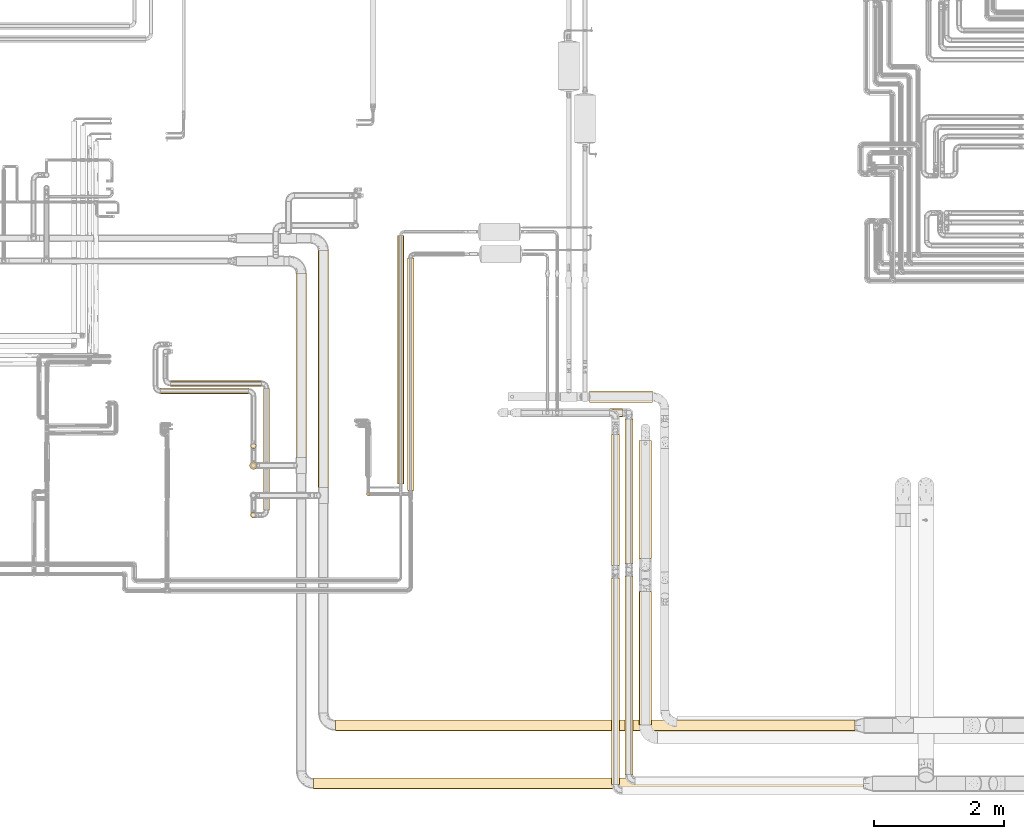
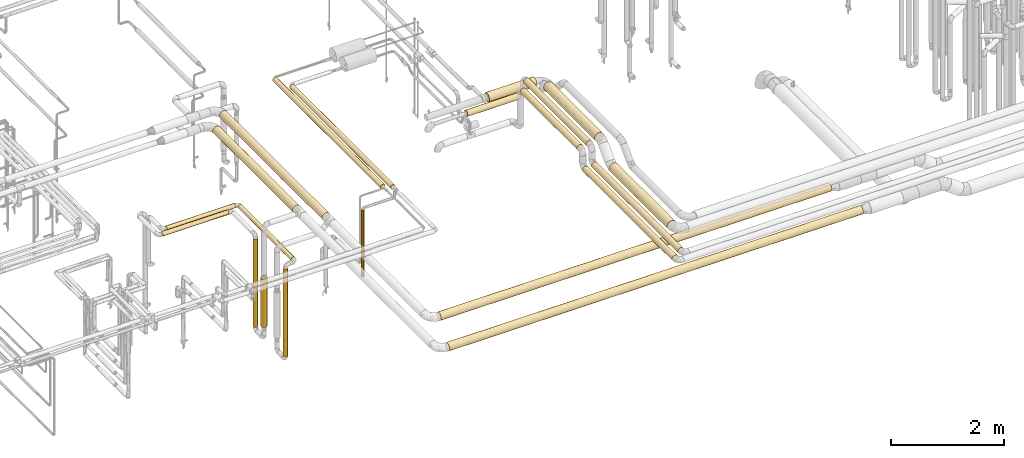
# One storey, part 2 of 827: 21 coverings.
"""IFC2X3 building model written with IfcOpenShell, lengths in millimetres."""

import ifcopenshell
import ifcopenshell.guid

model = None  # the IFC model being written
_history = None  # IfcOwnerHistory: only IFC2X3 demands one
_inside = {}  # id of a spatial element -> (the spatial element, [elements in it])
_under = {}  # id of a project, library or spatial element -> (it, [spatial elements below it])
_declared = {}  # id of a project -> (the project, [libraries it declares])
_typed = {}  # id of a type object -> (the type object, [elements of that type])
_made_of = {}  # id of a material, layer set ... -> (it, [elements and type objects made of it])


def new_model(schema):
    """Start an empty IFC model of exactly this schema.

    Asked for "IFC4X3", IfcOpenShell would pick the latest addendum, in which some entities
    have other attributes; the version numbers below select the first issue.
    IFC2X3 requires an IfcOwnerHistory on every rooted entity: one is made here for all.
    """
    global model, _history
    if schema == "IFC4X3":
        model = ifcopenshell.file(schema_version=(4, 3, 0, 0))
    else:
        model = ifcopenshell.file(schema=schema)
    _inside.clear()
    _under.clear()
    _declared.clear()
    _typed.clear()
    _made_of.clear()
    _history = None
    if model.schema == "IFC2X3":
        org = make("IfcOrganization", Name="unknown")
        user = make(
            "IfcPersonAndOrganization",
            ThePerson=make("IfcPerson", FamilyName="unknown"),
            TheOrganization=org,
        )
        app = make(
            "IfcApplication",
            ApplicationDeveloper=org,
            Version="unknown",
            ApplicationFullName="unknown",
            ApplicationIdentifier="unknown",
        )
        _history = make(
            "IfcOwnerHistory",
            OwningUser=user,
            OwningApplication=app,
            ChangeAction="ADDED",
            CreationDate=0,
        )
    return model


def make(cls, **values):
    """One entity of the class cls with the attributes given. An attribute that is None is left unset."""
    return model.create_entity(
        cls, **{name: value for name, value in values.items() if value is not None}
    )


def entity(cls, *values):
    """Any entity or typed value of the class cls, its attributes in the order of the schema. None: left unset."""
    e = model.create_entity(cls)
    for i, value in enumerate(values):
        if value is not None:
            e[i] = value
    return e


def rooted(cls, **values):
    """An entity with a GlobalId (a new one), such as an element, a storey or a relation."""
    return make(cls, GlobalId=ifcopenshell.guid.new(), OwnerHistory=_history, **values)


def si_unit(unit_type, name, prefix=None):
    """IfcSIUnit, for example si_unit("LENGTHUNIT", "METRE", prefix="MILLI")."""
    return make("IfcSIUnit", UnitType=unit_type, Prefix=prefix, Name=name)


def converted_unit(unit_type, name, factor, base, dimensions=None, offset=None):
    """IfcConversionBasedUnit, such as the inch: factor (a typed value) times the base unit."""
    return make(
        "IfcConversionBasedUnit"
        if offset is None
        else "IfcConversionBasedUnitWithOffset",
        ConversionOffset=offset,
        Dimensions=None
        if dimensions is None
        else entity("IfcDimensionalExponents", *dimensions),
        UnitType=unit_type,
        Name=name,
        ConversionFactor=make(
            "IfcMeasureWithUnit", ValueComponent=factor, UnitComponent=base
        ),
    )


def derived_unit(unit_type, elements):
    """IfcDerivedUnit: a product of units, each with its exponent."""
    return make(
        "IfcDerivedUnit",
        Elements=[
            make("IfcDerivedUnitElement", Unit=unit, Exponent=power)
            for unit, power in elements
        ],
        UnitType=unit_type,
    )


def assignment(units):
    """IfcUnitAssignment: the units of a project."""
    return None if units is None else make("IfcUnitAssignment", Units=units)


def point(xyz):
    """IfcCartesianPoint."""
    return None if xyz is None else make("IfcCartesianPoint", Coordinates=xyz)


def direction(xyz):
    """IfcDirection."""
    return None if xyz is None else make("IfcDirection", DirectionRatios=xyz)


def frame(location, z_axis=None, x_axis=None):
    """IfcAxis2Placement3D, a coordinate frame: its origin and axes. An axis left out is left unset."""
    return make(
        "IfcAxis2Placement3D",
        Location=point(location),
        Axis=direction(z_axis),
        RefDirection=direction(x_axis),
    )


def frame_2d(location, x_axis=None):
    """IfcAxis2Placement2D, a coordinate frame in the plane: its origin and x axis."""
    return make(
        "IfcAxis2Placement2D", Location=point(location), RefDirection=direction(x_axis)
    )


def origin():
    """The frame at (0, 0, 0) with its axes left unset."""
    return frame((0.0, 0.0, 0.0))


def origin_2d_with_axis():
    """The frame at (0, 0) in the plane with the x axis (1, 0) written out."""
    return frame_2d((0.0, 0.0), x_axis=(1.0, 0.0))


def place(relative_to, where):
    """IfcLocalPlacement: puts the frame where relative to a parent placement (None: the world)."""
    return make(
        "IfcLocalPlacement", PlacementRelTo=relative_to, RelativePlacement=where
    )


def context(
    kind, dimensions, precision=None, world=None, true_north=None, identifier=None
):
    """IfcGeometricRepresentationContext, for example the 3D "Model" context."""
    return make(
        "IfcGeometricRepresentationContext",
        ContextIdentifier=identifier,
        ContextType=kind,
        CoordinateSpaceDimension=dimensions,
        Precision=precision,
        WorldCoordinateSystem=world,
        TrueNorth=true_north,
    )


def subcontext(parent, identifier, kind, view, scale=None):
    """IfcGeometricRepresentationSubContext, for example "Body" below "Model"."""
    return make(
        "IfcGeometricRepresentationSubContext",
        ContextIdentifier=identifier,
        ContextType=kind,
        ParentContext=parent,
        TargetScale=scale,
        TargetView=view,
    )


def project(units=None, contexts=None):
    """IfcProject with its units and contexts."""
    return rooted(
        "IfcProject",
        Name="project",
        RepresentationContexts=contexts,
        UnitsInContext=assignment(units),
    )


def spatial(cls, under=None, at=None, **own):
    """A site, building, storey or space (cls), placed at a placement, below another one or the project."""
    s = rooted(cls, ObjectPlacement=at, **own)
    if under is not None:
        _under.setdefault(under.id(), (under, []))[1].append(s)
    return s


def profile(cls, at=None, kind="AREA", **sizes):
    """A parametric profile (cls). Its sizes go by their IFC names, for example OverallWidth=200.0."""
    return make(cls, ProfileType=kind, Position=at, **sizes)


def circle(**sizes):
    """IfcCircleProfileDef."""
    return profile("IfcCircleProfileDef", **sizes)


def extrude(swept, where, along, depth):
    """IfcExtrudedAreaSolid: the profile swept, set in the frame where, extruded along a direction by depth."""
    return make(
        "IfcExtrudedAreaSolid",
        SweptArea=swept,
        Position=where,
        ExtrudedDirection=direction(along),
        Depth=depth,
    )


def shape(context_of_items, identifier, shape_type, items):
    """IfcShapeRepresentation: the items that make up one representation, for example the "Body"."""
    return make(
        "IfcShapeRepresentation",
        ContextOfItems=context_of_items,
        RepresentationIdentifier=identifier,
        RepresentationType=shape_type,
        Items=items,
    )


def made_of(thing, what):
    """Note that an element or type object is made of a material, layer set ...; save() writes the relation."""
    if what is not None:
        _made_of.setdefault(what.id(), (what, []))[1].append(thing)
    return thing


def element(
    cls,
    number,
    at=None,
    inside=None,
    cuts=None,
    type_object=None,
    material=None,
    context=None,
    identifier="Body",
    shape_type=None,
    held_by="IfcProductDefinitionShape",
    body=None,
    shapes=None,
    **own,
):
    """One element of the class cls, such as IfcWall. Its Tag is "e" and its number.

    at: its placement. inside: the storey or other place that contains it. cuts: it is an
    opening in that element (IfcRelVoidsElement). A single representation is given by context,
    identifier, shape_type and body (its items); several are given by shapes. held_by: the class
    of the entity that holds the representations. save() writes the other relations.
    """
    e = rooted(cls, Tag="e%d" % number, ObjectPlacement=at, **own)
    if body is not None:
        shapes = [shape(context, identifier, shape_type, body)]
    if shapes is not None:
        e.Representation = make(held_by, Representations=shapes)
    if inside is not None:
        _inside.setdefault(inside.id(), (inside, []))[1].append(e)
    if cuts is not None:
        rooted(
            "IfcRelVoidsElement", RelatingBuildingElement=cuts, RelatedOpeningElement=e
        )
    if type_object is not None:
        _typed.setdefault(type_object.id(), (type_object, []))[1].append(e)
    return made_of(e, material)


def aggregate(whole, parts):
    """IfcRelAggregates: a whole, such as a stair, and the parts it consists of."""
    return rooted("IfcRelAggregates", RelatingObject=whole, RelatedObjects=parts)


def save(model, path):
    """Write the relations noted so far, then the file.

    IfcRelAggregates (storeys below a building ...), IfcRelContainedInSpatialStructure (elements
    in a storey), IfcRelDefinesByType, IfcRelAssociatesMaterial and IfcRelDeclares: one each for
    every whole, place, type object, material and project.
    """
    for whole, parts in _under.values():
        aggregate(whole, parts)
    for where, things in _inside.values():
        rooted(
            "IfcRelContainedInSpatialStructure",
            RelatedElements=things,
            RelatingStructure=where,
        )
    for kind, things in _typed.values():
        rooted("IfcRelDefinesByType", RelatedObjects=things, RelatingType=kind)
    for what, things in _made_of.values():
        rooted("IfcRelAssociatesMaterial", RelatedObjects=things, RelatingMaterial=what)
    for by, libraries in _declared.values():
        rooted("IfcRelDeclares", RelatingContext=by, RelatedDefinitions=libraries)
    model.write(path)


model = new_model("IFC2X3")

# Units and contexts
model_context = context("Model", 3, precision=0.01, world=origin(), true_north=direction((6.12303176911189e-17, 1.0)))
body_context = subcontext(model_context, "Body", "Model", "MODEL_VIEW")
ifc_project = project(units=[si_unit("LENGTHUNIT", "METRE", prefix="MILLI"), si_unit("AREAUNIT", "SQUARE_METRE"), si_unit("VOLUMEUNIT", "CUBIC_METRE"), converted_unit("PLANEANGLEUNIT", "DEGREE", entity("IfcRatioMeasure", 0.0174532925199433), si_unit("PLANEANGLEUNIT", "RADIAN"), dimensions=[0, 0, 0, 0, 0, 0, 0]), si_unit("MASSUNIT", "GRAM", prefix="KILO"), derived_unit("MASSDENSITYUNIT", [(si_unit("MASSUNIT", "GRAM", prefix="KILO"), 1), (si_unit("LENGTHUNIT", "METRE"), -3)]), derived_unit("MOMENTOFINERTIAUNIT", [(si_unit("LENGTHUNIT", "METRE"), 4)]), si_unit("TIMEUNIT", "SECOND"), si_unit("FREQUENCYUNIT", "HERTZ"), si_unit("THERMODYNAMICTEMPERATUREUNIT", "DEGREE_CELSIUS"), derived_unit("THERMALTRANSMITTANCEUNIT", [(si_unit("MASSUNIT", "GRAM", prefix="KILO"), 1), (si_unit("THERMODYNAMICTEMPERATUREUNIT", "KELVIN"), -1), (si_unit("TIMEUNIT", "SECOND"), -3)]), derived_unit("VOLUMETRICFLOWRATEUNIT", [(si_unit("LENGTHUNIT", "METRE"), 3), (si_unit("TIMEUNIT", "SECOND"), -1)]), derived_unit("MASSFLOWRATEUNIT", [(si_unit("MASSUNIT", "GRAM", prefix="KILO"), 1), (si_unit("TIMEUNIT", "SECOND"), -1)]), derived_unit("ROTATIONALFREQUENCYUNIT", [(si_unit("TIMEUNIT", "SECOND"), -1)]), si_unit("ELECTRICCURRENTUNIT", "AMPERE"), si_unit("ELECTRICVOLTAGEUNIT", "VOLT"), si_unit("POWERUNIT", "WATT"), si_unit("FORCEUNIT", "NEWTON", prefix="KILO"), si_unit("ILLUMINANCEUNIT", "LUX"), si_unit("LUMINOUSFLUXUNIT", "LUMEN"), si_unit("LUMINOUSINTENSITYUNIT", "CANDELA"), derived_unit("USERDEFINED", [(si_unit("MASSUNIT", "GRAM", prefix="KILO"), -1), (si_unit("LENGTHUNIT", "METRE"), -2), (si_unit("TIMEUNIT", "SECOND"), 3), (si_unit("LUMINOUSFLUXUNIT", "LUMEN"), 1)]), derived_unit("LINEARVELOCITYUNIT", [(si_unit("LENGTHUNIT", "METRE"), 1), (si_unit("TIMEUNIT", "SECOND"), -1)]), si_unit("PRESSUREUNIT", "PASCAL"), derived_unit("USERDEFINED", [(si_unit("LENGTHUNIT", "METRE"), -2), (si_unit("MASSUNIT", "GRAM", prefix="KILO"), 1), (si_unit("TIMEUNIT", "SECOND"), -2)]), derived_unit("LINEARFORCEUNIT", [(si_unit("MASSUNIT", "GRAM", prefix="KILO"), 1), (si_unit("LENGTHUNIT", "METRE"), 1), (si_unit("TIMEUNIT", "SECOND"), -2), (si_unit("LENGTHUNIT", "METRE"), -1)]), derived_unit("PLANARFORCEUNIT", [(si_unit("MASSUNIT", "GRAM", prefix="KILO"), 1), (si_unit("LENGTHUNIT", "METRE"), 1), (si_unit("TIMEUNIT", "SECOND"), -2), (si_unit("LENGTHUNIT", "METRE"), -2)])], contexts=[model_context])

# Site, building, storey
site_placement = place(None, origin())
site = spatial("IfcSite", under=ifc_project, at=site_placement, CompositionType="ELEMENT")
building_placement = place(site_placement, origin())
building = spatial("IfcBuilding", under=site, at=building_placement, CompositionType="ELEMENT")
storey_placement = place(building_placement, frame((0.0, 0.0, 28200.0)))
storey = spatial("IfcBuildingStorey", under=building, at=storey_placement, Name="08", CompositionType="ELEMENT", Elevation=28200.0)

# Coverings
covering_1_placement = place(storey_placement, frame((22834.37, 10792.39, 1329.67)))
element("IfcCovering", 1, at=covering_1_placement, inside=storey, Name=":ADSK_", ObjectType=":ADSK_", PredefinedType="INSULATION", context=body_context, shape_type="SweptSolid", body=[
    extrude(circle(Radius=28.4, at=origin_2d_with_axis()), frame((30.0, 30.0, 0.0), z_axis=(0.0, 0.0, 1.0), x_axis=(0.0, -1.0, 0.0)), (0.0, 0.0, 1.0), 1445.55000000002),
])
covering_2_placement = place(storey_placement, frame((22364.76, 7183.11, 2716.91)))
element("IfcCovering", 2, at=covering_2_placement, inside=storey, Name=":ADSK_", ObjectType=":ADSK_", PredefinedType="INSULATION", context=body_context, shape_type="SweptSolid", body=[
    extrude(circle(Radius=81.5, at=origin_2d_with_axis()), frame((0.0, 83.1, 83.1), z_axis=(1.0, 0.0, -1.4449984608822e-07), x_axis=(0.0, -1.0, 0.0)), (0.0, 0.0, 1.0), 7974.99960693687),
])
covering_3_placement = place(storey_placement, frame((22091.66, 10923.65, 2716.9)))
element("IfcCovering", 3, at=covering_3_placement, inside=storey, Name=":ADSK_", ObjectType=":ADSK_", PredefinedType="INSULATION", context=body_context, shape_type="SweptSolid", body=[
    extrude(circle(Radius=81.5, at=origin_2d_with_axis()), frame((83.1, 0.0, 83.1), z_axis=(0.0, 1.0, -7.43771752301072e-07), x_axis=(0.0, 7.43771752301072e-07, 1.0)), (0.0, 0.0, 1.0), 3636.14510383974),
])
covering_4_placement = place(storey_placement, frame((26803.29, 6511.57, 3035.65)))
element("IfcCovering", 4, at=covering_4_placement, inside=storey, Name=":ADSK_", ObjectType=":ADSK_", PredefinedType="INSULATION", context=body_context, shape_type="SweptSolid", body=[
    extrude(circle(Radius=62.75, at=origin_2d_with_axis()), frame((64.35, 0.0, 64.35), z_axis=(0.0, 1.0, 0.0), x_axis=(-1.0, 0.0, 0.0)), (0.0, 0.0, 1.0), 3050.00000000001),
])
covering_5_placement = place(storey_placement, frame((26599.29, 6360.71, 3035.65)))
element("IfcCovering", 5, at=covering_5_placement, inside=storey, Name=":ADSK_", ObjectType=":ADSK_", PredefinedType="INSULATION", context=body_context, shape_type="SweptSolid", body=[
    extrude(circle(Radius=62.75, at=origin_2d_with_axis()), frame((64.35, 0.0, 64.35), z_axis=(0.0, 1.0, 0.0), x_axis=(-1.0, 0.0, 0.0)), (0.0, 0.0, 1.0), 3170.00000000002),
])
covering_6_placement = place(storey_placement, frame((22025.11, 6291.9, 2716.9)))
element("IfcCovering", 6, at=covering_6_placement, inside=storey, Name=":ADSK_", ObjectType=":ADSK_", PredefinedType="INSULATION", context=body_context, shape_type="SweptSolid", body=[
    extrude(circle(Radius=81.5, at=origin_2d_with_axis()), frame((0.0, 83.1, 83.1), z_axis=(1.0, 0.0, 0.0), x_axis=(0.0, -1.0, 0.0)), (0.0, 0.0, 1.0), 8444.99999999997),
])
covering_7_placement = place(storey_placement, frame((21752.01, 11383.65, 2716.89)))
element("IfcCovering", 7, at=covering_7_placement, inside=storey, Name=":ADSK_", ObjectType=":ADSK_", PredefinedType="INSULATION", context=body_context, shape_type="SweptSolid", body=[
    extrude(circle(Radius=81.5, at=origin_2d_with_axis()), frame((83.1, 0.0, 83.11), z_axis=(0.0, 1.0, -6.05126980004747e-06), x_axis=(-1.0, 0.0, 0.0)), (0.0, 0.0, 1.0), 2826.34945677688),
])
covering_8_placement = place(storey_placement, frame((19826.0, 12474.23, 2353.4)))
element("IfcCovering", 8, at=covering_8_placement, inside=storey, Name=":ADSK_", ObjectType=":ADSK_", PredefinedType="INSULATION", context=body_context, shape_type="SweptSolid", body=[
    extrude(circle(Radius=45.0, at=origin_2d_with_axis()), frame((0.0, 46.6, 46.6), z_axis=(1.0, 0.0, 0.0), x_axis=(0.0, 1.0, 0.0)), (0.0, 0.0, 1.0), 1398.24219517759),
])
covering_9_placement = place(storey_placement, frame((21253.65, 10574.33, 2353.4)))
element("IfcCovering", 9, at=covering_9_placement, inside=storey, Name=":ADSK_", ObjectType=":ADSK_", PredefinedType="INSULATION", context=body_context, shape_type="SweptSolid", body=[
    extrude(circle(Radius=45.0, at=origin_2d_with_axis()), frame((46.6, 0.0, 46.6), z_axis=(0.0, 1.0, 0.0), x_axis=(1.0, 0.0, 0.0)), (0.0, 0.0, 1.0), 1870.50000000001),
])
covering_10_placement = place(storey_placement, frame((21053.7, 10451.73, 434.26)))
element("IfcCovering", 10, at=covering_10_placement, inside=storey, Name=":ADSK_", ObjectType=":ADSK_", PredefinedType="INSULATION", context=body_context, shape_type="SweptSolid", body=[
    extrude(circle(Radius=45.0, at=origin_2d_with_axis()), frame((46.6, 46.6, 0.0), z_axis=(0.0, 0.0, 1.0), x_axis=(0.0, -1.0, 0.0)), (0.0, 0.0, 1.0), 1889.74450477698),
])
covering_11_placement = place(storey_placement, frame((19674.0, 12356.27, 2353.4)))
element("IfcCovering", 11, at=covering_11_placement, inside=storey, Name=":ADSK_", ObjectType=":ADSK_", PredefinedType="INSULATION", context=body_context, shape_type="SweptSolid", body=[
    extrude(circle(Radius=45.0, at=origin_2d_with_axis()), frame((0.0, 46.6, 46.6), z_axis=(1.0, 0.0, 0.0), x_axis=(0.0, 1.0, 0.0)), (0.0, 0.0, 1.0), 1350.05414940568),
])
covering_12_placement = place(storey_placement, frame((21053.46, 11516.27, 426.01)))
element("IfcCovering", 12, at=covering_12_placement, inside=storey, Name=":ADSK_", ObjectType=":ADSK_", PredefinedType="INSULATION", context=body_context, shape_type="SweptSolid", body=[
    extrude(circle(Radius=45.0, at=origin_2d_with_axis()), frame((46.6, 46.6, 0.0), z_axis=(0.0, 0.0, 1.0), x_axis=(-1.0, 0.0, 0.0)), (0.0, 0.0, 1.0), 1897.99009936313),
])
covering_13_placement = place(storey_placement, frame((21039.21, 11198.8, 619.0)))
element("IfcCovering", 13, at=covering_13_placement, inside=storey, Name=":ADSK_", ObjectType=":ADSK_", PredefinedType="INSULATION", context=body_context, shape_type="SweptSolid", body=[
    extrude(circle(Radius=59.25, at=origin_2d_with_axis()), frame((60.85, 60.85, 0.0), z_axis=(0.0, 0.0, 1.0), x_axis=(0.0, 1.0, 0.0)), (0.0, 0.0, 1.0), 1037.76432267898),
])
covering_14_placement = place(storey_placement, frame((23312.72, 10979.27, 2947.53)))
element("IfcCovering", 14, at=covering_14_placement, inside=storey, Name=":ADSK_", ObjectType=":ADSK_", PredefinedType="INSULATION", context=body_context, shape_type="SweptSolid", body=[
    extrude(circle(Radius=49.0, at=origin_2d_with_axis()), frame((50.6, 0.0, 50.6), z_axis=(0.0, 1.0, 0.0), x_axis=(0.00137824167283797, 0.0, -0.999999050224495)), (0.0, 0.0, 1.0), 3814.3307462866),
])
covering_15_placement = place(storey_placement, frame((23463.79, 10879.39, 2945.89)))
element("IfcCovering", 15, at=covering_15_placement, inside=storey, Name=":ADSK_", ObjectType=":ADSK_", PredefinedType="INSULATION", context=body_context, shape_type="SweptSolid", body=[
    extrude(circle(Radius=49.0, at=origin_2d_with_axis()), frame((50.6, 0.0, 50.6), z_axis=(0.0, 1.0, 0.0), x_axis=(0.00144189846120528, 0.0, -0.999998960463873)), (0.0, 0.0, 1.0), 3569.23335100453),
])
covering_16_placement = place(storey_placement, frame((26599.29, 9720.71, 3385.65)))
element("IfcCovering", 16, at=covering_16_placement, inside=storey, Name=":ADSK_", ObjectType=":ADSK_", PredefinedType="INSULATION", context=body_context, shape_type="SweptSolid", body=[
    extrude(circle(Radius=62.75, at=origin_2d_with_axis()), frame((64.35, 0.0, 64.35), z_axis=(0.0, 1.0, 0.0), x_axis=(1.0, 0.0, 0.0)), (0.0, 0.0, 1.0), 2014.75005896576),
])
covering_17_placement = place(storey_placement, frame((26803.29, 9751.57, 3385.65)))
element("IfcCovering", 17, at=covering_17_placement, inside=storey, Name=":ADSK_", ObjectType=":ADSK_", PredefinedType="INSULATION", context=body_context, shape_type="SweptSolid", body=[
    extrude(circle(Radius=62.75, at=origin_2d_with_axis()), frame((64.35, 0.0, 64.35), z_axis=(0.0, 1.0, 0.0), x_axis=(-1.0, 0.0, 0.0)), (0.0, 0.0, 1.0), 2223.43633945695),
])
covering_18_placement = place(storey_placement, frame((27023.74, 9832.51, 3353.4)))
element("IfcCovering", 18, at=covering_18_placement, inside=storey, Name=":ADSK_", ObjectType=":ADSK_", PredefinedType="INSULATION", context=body_context, shape_type="SweptSolid", body=[
    extrude(circle(Radius=95.0, at=origin_2d_with_axis()), frame((96.6, 0.0, 96.6), z_axis=(0.0, 1.0, 0.0), x_axis=(1.0, 0.0, 0.0)), (0.0, 0.0, 1.0), 1807.94868526245),
])
covering_19_placement = place(storey_placement, frame((27023.74, 7270.0, 3003.4)))
element("IfcCovering", 19, at=covering_19_placement, inside=storey, Name=":ADSK_", ObjectType=":ADSK_", PredefinedType="INSULATION", context=body_context, shape_type="SweptSolid", body=[
    extrude(circle(Radius=95.0, at=origin_2d_with_axis()), frame((96.6, 0.0, 96.6), z_axis=(0.0, 1.0, 0.0), x_axis=(-1.0, 0.0, 0.0)), (0.0, 0.0, 1.0), 2055.10942162512),
])
covering_20_placement = place(storey_placement, frame((25692.18, 12005.66, 3035.65)))
element("IfcCovering", 20, at=covering_20_placement, inside=storey, Name=":ADSK_", ObjectType=":ADSK_", PredefinedType="INSULATION", context=body_context, shape_type="SweptSolid", body=[
    extrude(circle(Radius=62.75, at=origin_2d_with_axis()), frame((0.0, 64.35, 64.35), z_axis=(1.0, 0.0, 0.0), x_axis=(0.0, 1.0, 0.0)), (0.0, 0.0, 1.0), 1080.45905541786),
])
covering_21_placement = place(storey_placement, frame((26258.91, 12222.47, 3006.9)))
element("IfcCovering", 21, at=covering_21_placement, inside=storey, Name=":ADSK_", ObjectType=":ADSK_", PredefinedType="INSULATION", context=body_context, shape_type="SweptSolid", body=[
    extrude(circle(Radius=91.5, at=origin_2d_with_axis()), frame((0.0, 93.1, 93.1), z_axis=(1.0, 0.0, 0.0), x_axis=(0.0, 1.0, 0.0)), (0.0, 0.0, 1.0), 971.124054571153),
])

save(model, "model.ifc")
